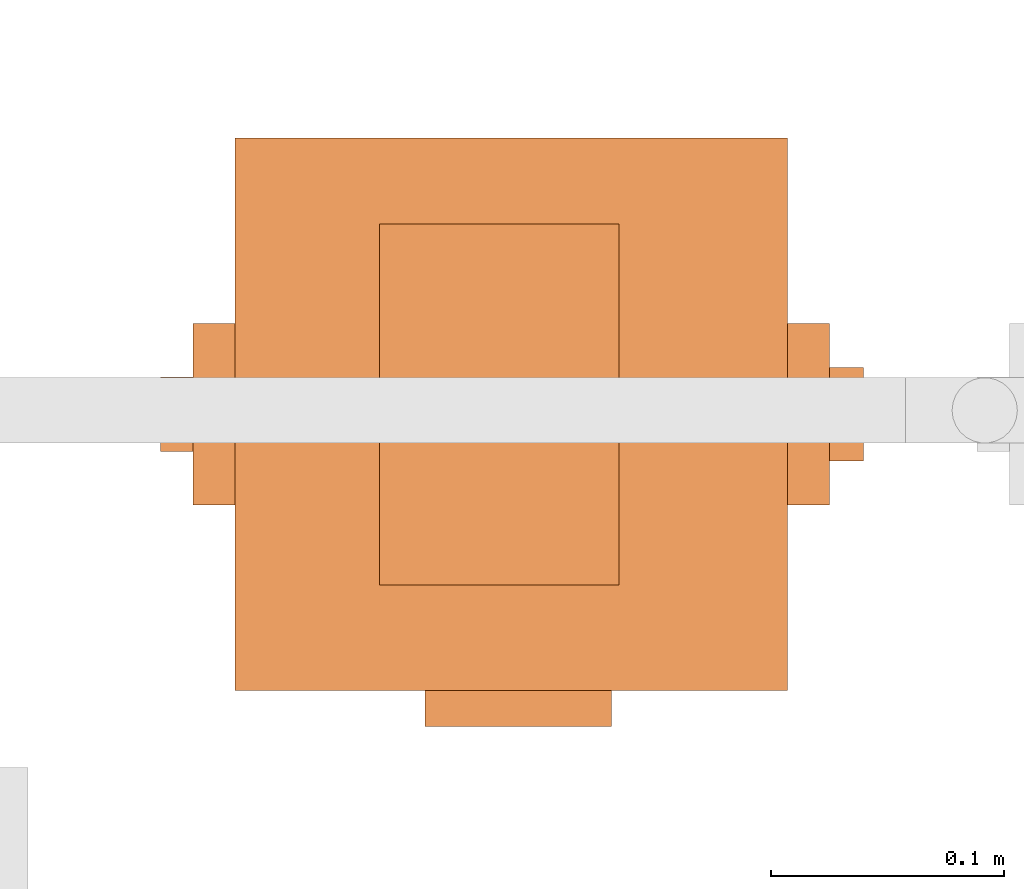
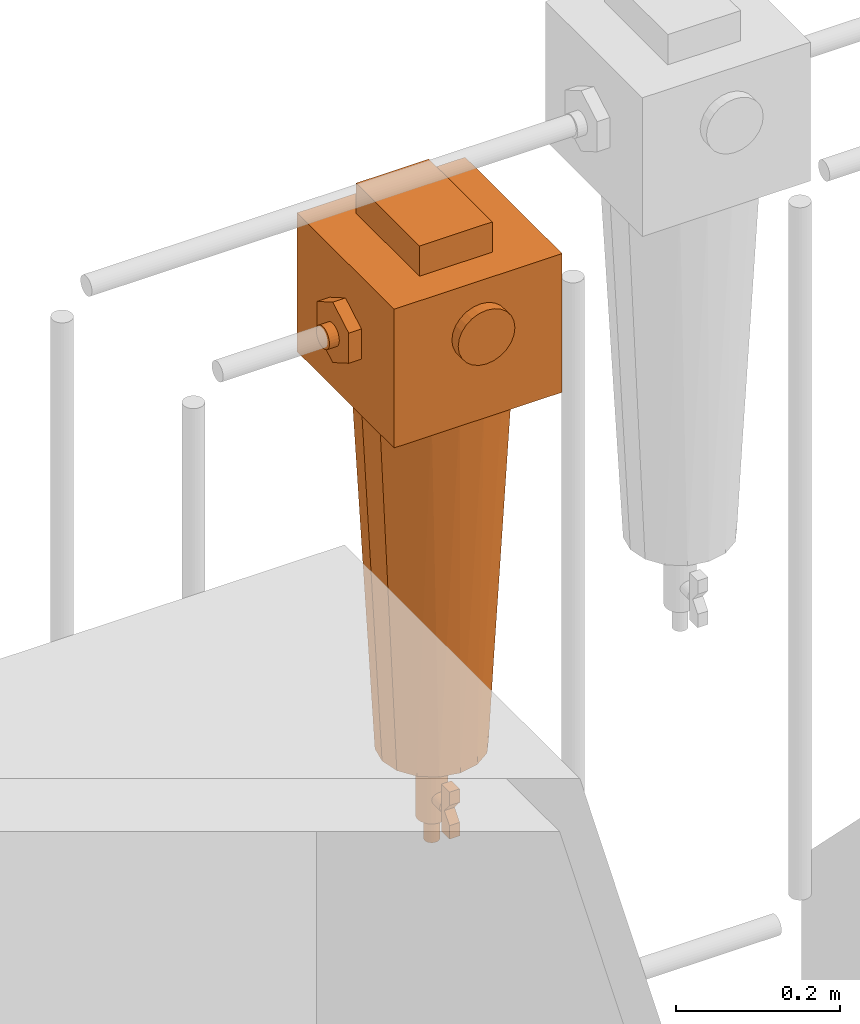
# One storey, part 328 of 331: 1 proxy.
"""IFC2X3 building model written with IfcOpenShell, lengths in millimetres."""

import ifcopenshell
import ifcopenshell.guid

model = None  # the IFC model being written
_history = None  # IfcOwnerHistory: only IFC2X3 demands one
_inside = {}  # id of a spatial element -> (the spatial element, [elements in it])
_under = {}  # id of a project, library or spatial element -> (it, [spatial elements below it])
_declared = {}  # id of a project -> (the project, [libraries it declares])
_typed = {}  # id of a type object -> (the type object, [elements of that type])
_made_of = {}  # id of a material, layer set ... -> (it, [elements and type objects made of it])


def new_model(schema):
    """Start an empty IFC model of exactly this schema.

    Asked for "IFC4X3", IfcOpenShell would pick the latest addendum, in which some entities
    have other attributes; the version numbers below select the first issue.
    IFC2X3 requires an IfcOwnerHistory on every rooted entity: one is made here for all.
    """
    global model, _history
    if schema == "IFC4X3":
        model = ifcopenshell.file(schema_version=(4, 3, 0, 0))
    else:
        model = ifcopenshell.file(schema=schema)
    _inside.clear()
    _under.clear()
    _declared.clear()
    _typed.clear()
    _made_of.clear()
    _history = None
    if model.schema == "IFC2X3":
        org = make("IfcOrganization", Name="unknown")
        user = make(
            "IfcPersonAndOrganization",
            ThePerson=make("IfcPerson", FamilyName="unknown"),
            TheOrganization=org,
        )
        app = make(
            "IfcApplication",
            ApplicationDeveloper=org,
            Version="unknown",
            ApplicationFullName="unknown",
            ApplicationIdentifier="unknown",
        )
        _history = make(
            "IfcOwnerHistory",
            OwningUser=user,
            OwningApplication=app,
            ChangeAction="ADDED",
            CreationDate=0,
        )
    return model


def make(cls, **values):
    """One entity of the class cls with the attributes given. An attribute that is None is left unset."""
    return model.create_entity(
        cls, **{name: value for name, value in values.items() if value is not None}
    )


def entity(cls, *values):
    """Any entity or typed value of the class cls, its attributes in the order of the schema. None: left unset."""
    e = model.create_entity(cls)
    for i, value in enumerate(values):
        if value is not None:
            e[i] = value
    return e


def rooted(cls, **values):
    """An entity with a GlobalId (a new one), such as an element, a storey or a relation."""
    return make(cls, GlobalId=ifcopenshell.guid.new(), OwnerHistory=_history, **values)


def si_unit(unit_type, name, prefix=None):
    """IfcSIUnit, for example si_unit("LENGTHUNIT", "METRE", prefix="MILLI")."""
    return make("IfcSIUnit", UnitType=unit_type, Prefix=prefix, Name=name)


def converted_unit(unit_type, name, factor, base, dimensions=None, offset=None):
    """IfcConversionBasedUnit, such as the inch: factor (a typed value) times the base unit."""
    return make(
        "IfcConversionBasedUnit"
        if offset is None
        else "IfcConversionBasedUnitWithOffset",
        ConversionOffset=offset,
        Dimensions=None
        if dimensions is None
        else entity("IfcDimensionalExponents", *dimensions),
        UnitType=unit_type,
        Name=name,
        ConversionFactor=make(
            "IfcMeasureWithUnit", ValueComponent=factor, UnitComponent=base
        ),
    )


def derived_unit(unit_type, elements):
    """IfcDerivedUnit: a product of units, each with its exponent."""
    return make(
        "IfcDerivedUnit",
        Elements=[
            make("IfcDerivedUnitElement", Unit=unit, Exponent=power)
            for unit, power in elements
        ],
        UnitType=unit_type,
    )


def assignment(units):
    """IfcUnitAssignment: the units of a project."""
    return None if units is None else make("IfcUnitAssignment", Units=units)


def point(xyz):
    """IfcCartesianPoint."""
    return None if xyz is None else make("IfcCartesianPoint", Coordinates=xyz)


def direction(xyz):
    """IfcDirection."""
    return None if xyz is None else make("IfcDirection", DirectionRatios=xyz)


def frame(location, z_axis=None, x_axis=None):
    """IfcAxis2Placement3D, a coordinate frame: its origin and axes. An axis left out is left unset."""
    return make(
        "IfcAxis2Placement3D",
        Location=point(location),
        Axis=direction(z_axis),
        RefDirection=direction(x_axis),
    )


def origin():
    """The frame at (0, 0, 0) with its axes left unset."""
    return frame((0.0, 0.0, 0.0))


def place(relative_to, where):
    """IfcLocalPlacement: puts the frame where relative to a parent placement (None: the world)."""
    return make(
        "IfcLocalPlacement", PlacementRelTo=relative_to, RelativePlacement=where
    )


def context(
    kind, dimensions, precision=None, world=None, true_north=None, identifier=None
):
    """IfcGeometricRepresentationContext, for example the 3D "Model" context."""
    return make(
        "IfcGeometricRepresentationContext",
        ContextIdentifier=identifier,
        ContextType=kind,
        CoordinateSpaceDimension=dimensions,
        Precision=precision,
        WorldCoordinateSystem=world,
        TrueNorth=true_north,
    )


def subcontext(parent, identifier, kind, view, scale=None):
    """IfcGeometricRepresentationSubContext, for example "Body" below "Model"."""
    return make(
        "IfcGeometricRepresentationSubContext",
        ContextIdentifier=identifier,
        ContextType=kind,
        ParentContext=parent,
        TargetScale=scale,
        TargetView=view,
    )


def project(units=None, contexts=None):
    """IfcProject with its units and contexts."""
    return rooted(
        "IfcProject",
        Name="project",
        RepresentationContexts=contexts,
        UnitsInContext=assignment(units),
    )


def spatial(cls, under=None, at=None, **own):
    """A site, building, storey or space (cls), placed at a placement, below another one or the project."""
    s = rooted(cls, ObjectPlacement=at, **own)
    if under is not None:
        _under.setdefault(under.id(), (under, []))[1].append(s)
    return s


def faces_of(points, faces, orient=None, outer=None):
    """IfcFace entities. A face is a list of loops; a loop is a list of indices into points, from 0.

    orient and outer hold one flag for each loop. By default every Orientation is true, the
    first loop of a face is its IfcFaceOuterBound and the others are IfcFaceBound.
    """
    made = []
    for i, loops in enumerate(faces):
        bounds = []
        for j, loop in enumerate(loops):
            is_outer = j == 0 if outer is None else outer[i][j]
            bounds.append(
                make(
                    "IfcFaceOuterBound" if is_outer else "IfcFaceBound",
                    Bound=make("IfcPolyLoop", Polygon=[points[k] for k in loop]),
                    Orientation=True if orient is None else orient[i][j],
                )
            )
        made.append(make("IfcFace", Bounds=bounds))
    return made


def faceted_brep(points, faces, orient=None, outer=None, voids=None):
    """IfcFacetedBrep: a solid bounded by flat faces; with voids (closed shells), ...WithVoids."""
    shared = [point(p) for p in points]
    hull = make("IfcClosedShell", CfsFaces=faces_of(shared, faces, orient, outer))
    if voids is None:
        return make("IfcFacetedBrep", Outer=hull)
    return make(
        "IfcFacetedBrepWithVoids",
        Outer=hull,
        Voids=[
            make(cls, CfsFaces=faces_of(shared, fs, o, b)) for cls, fs, o, b in voids
        ],
    )


def shape(context_of_items, identifier, shape_type, items):
    """IfcShapeRepresentation: the items that make up one representation, for example the "Body"."""
    return make(
        "IfcShapeRepresentation",
        ContextOfItems=context_of_items,
        RepresentationIdentifier=identifier,
        RepresentationType=shape_type,
        Items=items,
    )


def source(mapping_origin, context_of_items, identifier, shape_type, items):
    """IfcRepresentationMap: a shape defined once, which mapped items show again and again."""
    return make(
        "IfcRepresentationMap",
        MappingOrigin=mapping_origin,
        MappedRepresentation=shape(context_of_items, identifier, shape_type, items),
    )


def transform(
    local_origin,
    x_axis=None,
    y_axis=None,
    z_axis=None,
    scale=None,
    scale2=None,
    scale3=None,
    uniform=True,
):
    """IfcCartesianTransformationOperator3D, or its non-uniform kind. x_axis, y_axis, z_axis: its Axis1, 2, 3."""
    if uniform:
        return make(
            "IfcCartesianTransformationOperator3D",
            Axis1=direction(x_axis),
            Axis2=direction(y_axis),
            LocalOrigin=point(local_origin),
            Scale=scale,
            Axis3=direction(z_axis),
        )
    return make(
        "IfcCartesianTransformationOperator3DnonUniform",
        Axis1=direction(x_axis),
        Axis2=direction(y_axis),
        LocalOrigin=point(local_origin),
        Scale=scale,
        Axis3=direction(z_axis),
        Scale2=scale2,
        Scale3=scale3,
    )


def mapped(mapping_source, mapping_target):
    """IfcMappedItem: shows the shape of a source again, moved by a transform."""
    return make(
        "IfcMappedItem", MappingSource=mapping_source, MappingTarget=mapping_target
    )


def material(Name=None, Category=None):
    """IfcMaterial."""
    return make("IfcMaterial", Name=Name, Category=Category)


def material_list(materials):
    """IfcMaterialList."""
    return make("IfcMaterialList", Materials=materials)


def made_of(thing, what):
    """Note that an element or type object is made of a material, layer set ...; save() writes the relation."""
    if what is not None:
        _made_of.setdefault(what.id(), (what, []))[1].append(thing)
    return thing


def type_object(cls, material=None, **own):
    """A type object (cls), such as IfcWallType, which elements share."""
    return made_of(rooted(cls, **own), material)


def type_shapes(of_type, sources):
    """Give a type object the sources (RepresentationMaps) that its elements show as mapped items."""
    of_type.RepresentationMaps = sources


def element(
    cls,
    number,
    at=None,
    inside=None,
    cuts=None,
    type_object=None,
    material=None,
    context=None,
    identifier="Body",
    shape_type=None,
    held_by="IfcProductDefinitionShape",
    body=None,
    shapes=None,
    **own,
):
    """One element of the class cls, such as IfcWall. Its Tag is "e" and its number.

    at: its placement. inside: the storey or other place that contains it. cuts: it is an
    opening in that element (IfcRelVoidsElement). A single representation is given by context,
    identifier, shape_type and body (its items); several are given by shapes. held_by: the class
    of the entity that holds the representations. save() writes the other relations.
    """
    e = rooted(cls, Tag="e%d" % number, ObjectPlacement=at, **own)
    if body is not None:
        shapes = [shape(context, identifier, shape_type, body)]
    if shapes is not None:
        e.Representation = make(held_by, Representations=shapes)
    if inside is not None:
        _inside.setdefault(inside.id(), (inside, []))[1].append(e)
    if cuts is not None:
        rooted(
            "IfcRelVoidsElement", RelatingBuildingElement=cuts, RelatedOpeningElement=e
        )
    if type_object is not None:
        _typed.setdefault(type_object.id(), (type_object, []))[1].append(e)
    return made_of(e, material)


def aggregate(whole, parts):
    """IfcRelAggregates: a whole, such as a stair, and the parts it consists of."""
    return rooted("IfcRelAggregates", RelatingObject=whole, RelatedObjects=parts)


def save(model, path):
    """Write the relations noted so far, then the file.

    IfcRelAggregates (storeys below a building ...), IfcRelContainedInSpatialStructure (elements
    in a storey), IfcRelDefinesByType, IfcRelAssociatesMaterial and IfcRelDeclares: one each for
    every whole, place, type object, material and project.
    """
    for whole, parts in _under.values():
        aggregate(whole, parts)
    for where, things in _inside.values():
        rooted(
            "IfcRelContainedInSpatialStructure",
            RelatedElements=things,
            RelatingStructure=where,
        )
    for kind, things in _typed.values():
        rooted("IfcRelDefinesByType", RelatedObjects=things, RelatingType=kind)
    for what, things in _made_of.values():
        rooted("IfcRelAssociatesMaterial", RelatedObjects=things, RelatingMaterial=what)
    for by, libraries in _declared.values():
        rooted("IfcRelDeclares", RelatingContext=by, RelatedDefinitions=libraries)
    model.write(path)


model = new_model("IFC2X3")

# Units and contexts
model_context = context("Model", 3, precision=0.01, world=origin(), true_north=direction((6.12303176911189e-17, 1.0)))
body_context = subcontext(model_context, "Body", "Model", "MODEL_VIEW")
ifc_project = project(units=[si_unit("LENGTHUNIT", "METRE", prefix="MILLI"), si_unit("AREAUNIT", "SQUARE_METRE"), si_unit("VOLUMEUNIT", "CUBIC_METRE"), converted_unit("PLANEANGLEUNIT", "DEGREE", entity("IfcRatioMeasure", 0.0174532925199433), si_unit("PLANEANGLEUNIT", "RADIAN"), dimensions=[0, 0, 0, 0, 0, 0, 0]), si_unit("MASSUNIT", "GRAM", prefix="KILO"), derived_unit("MASSDENSITYUNIT", [(si_unit("MASSUNIT", "GRAM", prefix="KILO"), 1), (si_unit("LENGTHUNIT", "METRE"), -3)]), derived_unit("MOMENTOFINERTIAUNIT", [(si_unit("LENGTHUNIT", "METRE"), 4)]), si_unit("TIMEUNIT", "SECOND"), si_unit("FREQUENCYUNIT", "HERTZ"), si_unit("THERMODYNAMICTEMPERATUREUNIT", "DEGREE_CELSIUS"), derived_unit("THERMALTRANSMITTANCEUNIT", [(si_unit("MASSUNIT", "GRAM", prefix="KILO"), 1), (si_unit("THERMODYNAMICTEMPERATUREUNIT", "KELVIN"), -1), (si_unit("TIMEUNIT", "SECOND"), -3)]), derived_unit("VOLUMETRICFLOWRATEUNIT", [(si_unit("LENGTHUNIT", "METRE"), 3), (si_unit("TIMEUNIT", "SECOND"), -1)]), derived_unit("MASSFLOWRATEUNIT", [(si_unit("MASSUNIT", "GRAM", prefix="KILO"), 1), (si_unit("TIMEUNIT", "SECOND"), -1)]), derived_unit("ROTATIONALFREQUENCYUNIT", [(si_unit("TIMEUNIT", "SECOND"), -1)]), si_unit("ELECTRICCURRENTUNIT", "AMPERE"), si_unit("ELECTRICVOLTAGEUNIT", "VOLT"), si_unit("POWERUNIT", "WATT"), si_unit("FORCEUNIT", "NEWTON", prefix="KILO"), si_unit("ILLUMINANCEUNIT", "LUX"), si_unit("LUMINOUSFLUXUNIT", "LUMEN"), si_unit("LUMINOUSINTENSITYUNIT", "CANDELA"), derived_unit("USERDEFINED", [(si_unit("MASSUNIT", "GRAM", prefix="KILO"), -1), (si_unit("LENGTHUNIT", "METRE"), -2), (si_unit("TIMEUNIT", "SECOND"), 3), (si_unit("LUMINOUSFLUXUNIT", "LUMEN"), 1)]), derived_unit("LINEARVELOCITYUNIT", [(si_unit("LENGTHUNIT", "METRE"), 1), (si_unit("TIMEUNIT", "SECOND"), -1)]), si_unit("PRESSUREUNIT", "PASCAL"), derived_unit("USERDEFINED", [(si_unit("LENGTHUNIT", "METRE"), -2), (si_unit("MASSUNIT", "GRAM", prefix="KILO"), 1), (si_unit("TIMEUNIT", "SECOND"), -2)]), derived_unit("LINEARFORCEUNIT", [(si_unit("MASSUNIT", "GRAM", prefix="KILO"), 1), (si_unit("LENGTHUNIT", "METRE"), 1), (si_unit("TIMEUNIT", "SECOND"), -2), (si_unit("LENGTHUNIT", "METRE"), -1)]), derived_unit("PLANARFORCEUNIT", [(si_unit("MASSUNIT", "GRAM", prefix="KILO"), 1), (si_unit("LENGTHUNIT", "METRE"), 1), (si_unit("TIMEUNIT", "SECOND"), -2), (si_unit("LENGTHUNIT", "METRE"), -2)])], contexts=[model_context])

# Site, building, storey
site_placement = place(None, frame((0.0, -0.00077364408347762, 0.0)))
site = spatial("IfcSite", under=ifc_project, at=site_placement, CompositionType="ELEMENT")
building_placement = place(site_placement, origin())
building = spatial("IfcBuilding", under=site, at=building_placement, CompositionType="ELEMENT")
storey_placement = place(building_placement, origin())
storey = spatial("IfcBuildingStorey", under=building, at=storey_placement, CompositionType="ELEMENT", Elevation=0.0)

# Proxy
ifc_material_1 = material()
ifc_material_2 = material()
ifc_material_list = material_list([ifc_material_1, ifc_material_2])
building_element_proxy_type = type_object("IfcBuildingElementProxyType", PredefinedType="NOTDEFINED", material=ifc_material_1)
shared_shape = source(origin(), body_context, "Body", "Brep", [
    faceted_brep([(0.0, -133.944326212679, 215.362410286268), (-10.3527618041006, -133.944326212679, 213.999443337831), (-20.0, -133.944326212679, 210.003426437646), (-28.2842712474617, -133.944326212679, 203.64668153373), (-34.6410161513774, -133.944326212679, 195.362410286268), (-38.6370330515627, -133.944326212679, 185.715172090369), (-40.0, -133.944326212679, 175.362410286268), (-38.6370330515627, -133.944326212679, 165.009648482167), (-34.6410161513776, -133.944326212679, 155.362410286268), (-28.2842712474619, -133.944326212679, 147.078139038806), (-20.0, -133.944326212679, 140.721394134891), (-10.3527618041009, -133.944326212679, 136.725377234705), (0.0, -133.944326212679, 135.362410286268), (10.3527618041008, -133.944326212679, 136.725377234705), (20.0, -133.944326212679, 140.721394134891), (28.2842712474618, -133.944326212679, 147.078139038806), (34.6410161513775, -133.944326212679, 155.362410286268), (38.6370330515627, -133.944326212679, 165.009648482167), (40.0, -133.944326212679, 175.362410286268), (38.6370330515628, -133.944326212679, 185.715172090369), (34.6410161513776, -133.944326212679, 195.362410286268), (28.284271247462, -133.944326212679, 203.64668153373), (20.0, -133.944326212679, 210.003426437646), (10.352761804101, -133.944326212679, 213.999443337831), (0.0, -118.499999999999, 135.362410286268), (-10.3527618041009, -118.499999999999, 136.725377234705), (-20.0, -118.499999999999, 140.721394134891), (-28.2842712474619, -118.499999999999, 147.078139038806), (-34.6410161513776, -118.499999999999, 155.362410286268), (-38.6370330515627, -118.499999999999, 165.009648482167), (-40.0, -118.499999999999, 175.362410286268), (-38.6370330515627, -118.499999999999, 185.715172090369), (-34.6410161513774, -118.499999999999, 195.362410286268), (-28.2842712474617, -118.499999999999, 203.64668153373), (-20.0, -118.499999999999, 210.003426437646), (-10.3527618041006, -118.499999999999, 213.999443337831), (0.0, -118.499999999999, 215.362410286268), (10.352761804101, -118.499999999999, 213.999443337831), (20.0, -118.499999999999, 210.003426437646), (28.284271247462, -118.499999999999, 203.64668153373), (34.6410161513776, -118.499999999999, 195.362410286268), (38.6370330515628, -118.499999999999, 185.715172090369), (40.0, -118.499999999999, 175.362410286268), (38.6370330515627, -118.499999999999, 165.009648482167), (34.6410161513775, -118.499999999999, 155.362410286268), (28.2842712474618, -118.499999999999, 147.078139038806), (20.0, -118.499999999999, 140.721394134891), (10.3527618041008, -118.499999999999, 136.725377234705)], [[[0, 1, 2, 3, 4, 5, 6, 7, 8, 9, 10, 11, 12, 13, 14, 15, 16, 17, 18, 19, 20, 21, 22, 23]], [[24, 25, 26, 27, 28, 29, 30, 31, 32, 33, 34, 35, 36, 37, 38, 39, 40, 41, 42, 43, 44, 45, 46, 47]], [[41, 19, 18, 42]], [[40, 20, 19, 41]], [[22, 21, 39, 38]], [[40, 39, 21, 20]], [[23, 22, 38, 37]], [[0, 23, 37, 36]], [[35, 1, 0, 36]], [[34, 2, 1, 35]], [[4, 3, 33, 32]], [[34, 33, 3, 2]], [[5, 4, 32, 31]], [[6, 5, 31, 30]], [[29, 7, 6, 30]], [[28, 8, 7, 29]], [[10, 9, 27, 26]], [[28, 27, 9, 8]], [[11, 10, 26, 25]], [[12, 11, 25, 24]], [[47, 13, 12, 24]], [[46, 14, 13, 47]], [[16, 15, 45, 44]], [[46, 45, 15, 14]], [[17, 16, 44, 43]], [[18, 17, 43, 42]]]),
    faceted_brep([(43.1099584355239, 81.5000000000009, 295.027035784925), (-59.5, 81.5000000000009, 295.027035784925), (-59.5, -73.1694472627613, 295.027035784925), (43.1099584355239, -73.1694472627613, 295.027035784925), (43.1099584355239, 81.5000000000009, 250.0), (43.1099584355239, -73.1694472627613, 250.0), (-59.5, -73.1694472627613, 250.0), (-59.5, 81.5000000000009, 250.0)], [[[0, 1, 2, 3]], [[4, 5, 6, 7]], [[1, 0, 4, 7]], [[2, 1, 7, 6]], [[3, 2, 6, 5]], [[0, 3, 5, 4]]]),
    faceted_brep([(6.83332917429858, -36.7004123407108, -547.095544544356), (6.83332917429858, -56.7004123407108, -547.095544544356), (6.83332917429858, -56.7004123407108, -567.095544544356), (6.83332917429858, -44.1139178730516, -582.095544544356), (6.83332917429858, -56.7004123407108, -597.095544544356), (6.83332917429858, -56.7004123407109, -617.095544544356), (6.83332917429858, -36.7004123407109, -617.095544544356), (6.83332917429858, -36.7004123407108, -582.095544544356), (-7.69905295378288, -36.7004123407108, -547.095544544356), (-7.69905295378288, -36.7004123407108, -582.095544544356), (-7.69905295378288, -36.7004123407109, -617.095544544356), (-7.69905295378288, -56.7004123407109, -617.095544544356), (-7.69905295378288, -56.7004123407108, -597.095544544356), (-7.69905295378288, -44.1139178730516, -582.095544544356), (-7.69905295378288, -56.7004123407108, -567.095544544356), (-7.69905295378288, -56.7004123407108, -547.095544544356)], [[[0, 1, 2, 3, 4, 5, 6, 7]], [[8, 9, 10, 11, 12, 13, 14, 15]], [[1, 0, 8, 15]], [[2, 1, 15, 14]], [[3, 2, 14, 13]], [[4, 3, 13, 12]], [[5, 4, 12, 11]], [[6, 5, 11, 10]], [[7, 6, 10, 9]], [[0, 7, 9, 8]]]),
    faceted_brep([(-5.0, -36.7004123407108, -573.435290506511), (-7.07106781186544, -36.7004123407108, -575.02447673249), (-8.66025403784436, -36.7004123407108, -577.095544544356), (-9.65925826289067, -36.7004123407108, -579.50735409333), (-10.0, -36.7004123407108, -582.095544544356), (-9.65925826289068, -36.7004123407108, -584.683734995381), (-8.66025403784439, -36.7004123407108, -587.095544544356), (-7.07106781186548, -36.7004123407108, -589.166612356221), (-5.0, -36.7004123407108, -590.7557985822), (-2.58819045102522, -36.7004123407108, -591.754802807246), (0.0, -36.7004123407108, -592.095544544356), (2.58819045102519, -36.7004123407108, -591.754802807246), (5.0, -36.7004123407108, -590.7557985822), (7.07106781186546, -36.7004123407108, -589.166612356221), (8.66025403784437, -36.7004123407108, -587.095544544356), (9.65925826289068, -36.7004123407108, -584.683734995381), (10.0, -36.7004123407108, -582.095544544356), (9.65925826289069, -36.7004123407108, -579.50735409333), (8.66025403784441, -36.7004123407108, -577.095544544356), (7.0710678118655, -36.7004123407108, -575.02447673249), (5.0, -36.7004123407108, -573.435290506511), (2.58819045102525, -36.7004123407108, -572.436286281465), (0.0, -36.7004123407108, -572.095544544356), (-2.58819045102516, -36.7004123407108, -572.436286281465), (2.58819045102519, -9.5868948994194, -591.754802807246), (0.0, -9.5868948994194, -592.095544544356), (-2.58819045102522, -9.5868948994194, -591.754802807246), (-5.0, -9.5868948994194, -590.7557985822), (-7.07106781186548, -9.5868948994194, -589.166612356221), (-8.66025403784439, -9.5868948994194, -587.095544544356), (-9.65925826289068, -9.5868948994194, -584.683734995381), (-10.0, -9.5868948994194, -582.095544544356), (-9.65925826289067, -9.5868948994194, -579.50735409333), (-8.66025403784436, -9.5868948994194, -577.095544544356), (-7.07106781186544, -9.5868948994194, -575.02447673249), (-5.0, -9.5868948994194, -573.435290506511), (-2.58819045102516, -9.5868948994194, -572.436286281465), (0.0, -9.5868948994194, -572.095544544356), (2.58819045102525, -9.5868948994194, -572.436286281465), (5.0, -9.5868948994194, -573.435290506511), (7.0710678118655, -9.5868948994194, -575.02447673249), (8.66025403784441, -9.5868948994194, -577.095544544356), (9.65925826289069, -9.5868948994194, -579.50735409333), (10.0, -9.5868948994194, -582.095544544356), (9.65925826289068, -9.5868948994194, -584.683734995381), (8.66025403784437, -9.5868948994194, -587.095544544356), (7.07106781186546, -9.5868948994194, -589.166612356221), (5.0, -9.5868948994194, -590.7557985822)], [[[0, 1, 2, 3, 4, 5, 6, 7, 8, 9, 10, 11, 12, 13, 14, 15, 16, 17, 18, 19, 20, 21, 22, 23]], [[24, 25, 26, 27, 28, 29, 30, 31, 32, 33, 34, 35, 36, 37, 38, 39, 40, 41, 42, 43, 44, 45, 46, 47]], [[42, 17, 16, 43]], [[41, 18, 17, 42]], [[20, 19, 40, 39]], [[41, 40, 19, 18]], [[21, 20, 39, 38]], [[22, 21, 38, 37]], [[36, 23, 22, 37]], [[35, 0, 23, 36]], [[2, 1, 34, 33]], [[35, 34, 1, 0]], [[3, 2, 33, 32]], [[4, 3, 32, 31]], [[30, 5, 4, 31]], [[29, 6, 5, 30]], [[8, 7, 28, 27]], [[29, 28, 7, 6]], [[9, 8, 27, 26]], [[10, 9, 26, 25]], [[24, 11, 10, 25]], [[47, 12, 11, 24]], [[14, 13, 46, 45]], [[47, 46, 13, 12]], [[15, 14, 45, 44]], [[16, 15, 44, 43]]]),
    faceted_brep([(5.17638090205032, -19.3185165257814, -545.770195770574), (10.0, -17.3205080756888, -545.770195770574), (14.1421356237309, -14.142135623731, -545.770195770574), (17.3205080756887, -10.0, -545.770195770574), (19.3185165257813, -5.17638090205054, -545.770195770574), (20.0, 0.0, -545.770195770574), (19.3185165257814, 5.17638090205041, -545.770195770574), (17.3205080756888, 10.0, -545.770195770574), (14.142135623731, 14.1421356237309, -545.770195770574), (10.0, 17.3205080756888, -545.770195770574), (5.17638090205044, 19.3185165257814, -545.770195770574), (0.0, 20.0, -545.770195770574), (-5.17638090205038, 19.3185165257814, -545.770195770574), (-10.0, 17.3205080756888, -545.770195770574), (-14.1421356237309, 14.142135623731, -545.770195770574), (-17.3205080756888, 10.0, -545.770195770574), (-19.3185165257814, 5.17638090205047, -545.770195770574), (-20.0, 0.0, -545.770195770574), (-19.3185165257814, -5.17638090205035, -545.770195770574), (-17.3205080756888, -10.0, -545.770195770574), (-14.142135623731, -14.1421356237309, -545.770195770574), (-10.0, -17.3205080756887, -545.770195770574), (-5.1763809020505, -19.3185165257813, -545.770195770574), (0.0, -20.0, -545.770195770574), (0.0, 20.0, -617.574154599676), (5.17638090205044, 19.3185165257814, -617.574154599676), (10.0, 17.3205080756888, -617.574154599676), (14.142135623731, 14.1421356237309, -617.574154599676), (17.3205080756888, 10.0, -617.574154599676), (19.3185165257814, 5.17638090205041, -617.574154599676), (20.0, 0.0, -617.574154599676), (19.3185165257813, -5.17638090205054, -617.574154599676), (17.3205080756887, -10.0, -617.574154599676), (14.1421356237309, -14.142135623731, -617.574154599676), (10.0, -17.3205080756888, -617.574154599676), (5.17638090205032, -19.3185165257814, -617.574154599676), (0.0, -20.0, -617.574154599676), (-5.1763809020505, -19.3185165257813, -617.574154599676), (-10.0, -17.3205080756887, -617.574154599676), (-14.142135623731, -14.1421356237309, -617.574154599676), (-17.3205080756888, -10.0, -617.574154599676), (-19.3185165257814, -5.17638090205035, -617.574154599676), (-20.0, 0.0, -617.574154599676), (-19.3185165257814, 5.17638090205047, -617.574154599676), (-17.3205080756888, 10.0, -617.574154599676), (-14.1421356237309, 14.142135623731, -617.574154599676), (-10.0, 17.3205080756888, -617.574154599676), (-5.17638090205038, 19.3185165257814, -617.574154599676)], [[[0, 1, 2, 3, 4, 5, 6, 7, 8, 9, 10, 11, 12, 13, 14, 15, 16, 17, 18, 19, 20, 21, 22, 23]], [[24, 25, 26, 27, 28, 29, 30, 31, 32, 33, 34, 35, 36, 37, 38, 39, 40, 41, 42, 43, 44, 45, 46, 47]], [[18, 41, 40, 19]], [[39, 20, 19, 40]], [[21, 38, 37, 22]], [[39, 38, 21, 20]], [[22, 37, 36, 23]], [[41, 18, 17, 42]], [[0, 35, 34, 1]], [[33, 2, 1, 34]], [[3, 32, 31, 4]], [[33, 32, 3, 2]], [[4, 31, 30, 5]], [[35, 0, 23, 36]], [[30, 29, 6, 5]], [[9, 26, 25, 10]], [[26, 9, 8, 27]], [[10, 25, 24, 11]], [[29, 28, 7, 6]], [[28, 27, 8, 7]], [[12, 47, 46, 13]], [[45, 14, 13, 46]], [[15, 44, 43, 16]], [[45, 44, 15, 14]], [[16, 43, 42, 17]], [[47, 12, 11, 24]]]),
    faceted_brep([(2.58819045102516, -9.6592582628907, -513.126445637314), (5.0, -8.66025403784441, -513.126445637314), (7.07106781186544, -7.07106781186551, -513.126445637314), (8.66025403784436, -5.0, -513.126445637314), (9.65925826289067, -2.58819045102527, -513.126445637314), (10.0, 0.0, -513.126445637314), (9.65925826289068, 2.58819045102521, -513.126445637314), (8.66025403784439, 5.0, -513.126445637314), (7.07106781186548, 7.07106781186547, -513.126445637314), (5.0, 8.66025403784438, -513.126445637314), (2.58819045102522, 9.65925826289068, -513.126445637314), (0.0, 10.0, -513.126445637314), (-2.58819045102519, 9.65925826289069, -513.126445637314), (-5.0, 8.6602540378444, -513.126445637314), (-7.07106781186546, 7.07106781186549, -513.126445637314), (-8.66025403784437, 5.0, -513.126445637314), (-9.65925826289068, 2.58819045102524, -513.126445637314), (-10.0, 0.0, -513.126445637314), (-9.65925826289069, -2.58819045102517, -513.126445637314), (-8.66025403784441, -5.0, -513.126445637314), (-7.0710678118655, -7.07106781186545, -513.126445637314), (-5.0, -8.66025403784437, -513.126445637314), (-2.58819045102525, -9.65925826289067, -513.126445637314), (0.0, -10.0, -513.126445637314), (0.0, 10.0, -652.602700358113), (2.58819045102522, 9.65925826289068, -652.602700358113), (5.0, 8.66025403784438, -652.602700358113), (7.07106781186548, 7.07106781186547, -652.602700358113), (8.66025403784439, 5.0, -652.602700358113), (9.65925826289068, 2.58819045102521, -652.602700358113), (10.0, 0.0, -652.602700358113), (9.65925826289067, -2.58819045102527, -652.602700358113), (8.66025403784436, -5.0, -652.602700358113), (7.07106781186544, -7.07106781186551, -652.602700358113), (5.0, -8.66025403784441, -652.602700358113), (2.58819045102516, -9.6592582628907, -652.602700358113), (0.0, -10.0, -652.602700358113), (-2.58819045102525, -9.65925826289067, -652.602700358113), (-5.0, -8.66025403784437, -652.602700358113), (-7.0710678118655, -7.07106781186545, -652.602700358113), (-8.66025403784441, -5.0, -652.602700358113), (-9.65925826289069, -2.58819045102517, -652.602700358113), (-10.0, 0.0, -652.602700358113), (-9.65925826289068, 2.58819045102524, -652.602700358113), (-8.66025403784437, 5.0, -652.602700358113), (-7.07106781186546, 7.07106781186549, -652.602700358113), (-5.0, 8.6602540378444, -652.602700358113), (-2.58819045102519, 9.65925826289069, -652.602700358113)], [[[0, 1, 2, 3, 4, 5, 6, 7, 8, 9, 10, 11, 12, 13, 14, 15, 16, 17, 18, 19, 20, 21, 22, 23]], [[24, 25, 26, 27, 28, 29, 30, 31, 32, 33, 34, 35, 36, 37, 38, 39, 40, 41, 42, 43, 44, 45, 46, 47]], [[41, 18, 17, 42]], [[40, 19, 18, 41]], [[21, 20, 39, 38]], [[40, 39, 20, 19]], [[22, 21, 38, 37]], [[23, 22, 37, 36]], [[35, 0, 23, 36]], [[3, 32, 31, 4]], [[32, 3, 2, 33]], [[4, 31, 30, 5]], [[0, 35, 34, 1]], [[1, 34, 33, 2]], [[29, 6, 5, 30]], [[28, 7, 6, 29]], [[9, 8, 27, 26]], [[28, 27, 8, 7]], [[9, 26, 25, 10]], [[24, 11, 10, 25]], [[14, 13, 46, 45]], [[15, 44, 43, 16]], [[45, 44, 15, 14]], [[16, 43, 42, 17]], [[47, 46, 13, 12]], [[12, 11, 24, 47]]]),
    faceted_brep([(-121.5, 0.0, 105.0), (-121.5, 38.9711431702997, 127.5), (-121.5, 38.9711431702998, 172.5), (-121.5, 0.0, 195.0), (-121.5, -38.9711431702996, 172.500000000001), (-121.5, -38.9711431702999, 127.500000000001), (-139.459825523657, 0.0, 105.0), (-139.459825523657, -38.9711431702999, 127.500000000001), (-139.459825523657, -38.9711431702996, 172.500000000001), (-139.459825523657, 0.0, 195.0), (-139.459825523657, 38.9711431702998, 172.5), (-139.459825523657, 38.9711431702997, 127.5)], [[[0, 1, 2, 3, 4, 5]], [[6, 7, 8, 9, 10, 11]], [[1, 0, 6, 11]], [[2, 1, 11, 10]], [[3, 2, 10, 9]], [[4, 3, 9, 8]], [[5, 4, 8, 7]], [[0, 5, 7, 6]]]),
    faceted_brep([(133.459825523657, 0.0, 105.0), (133.459825523657, 38.9711431702997, 127.5), (133.459825523657, 38.9711431702998, 172.5), (133.459825523657, 0.0, 195.0), (133.459825523657, -38.9711431702996, 172.5), (133.459825523657, -38.9711431702999, 127.5), (115.5, 0.0, 105.0), (115.5, -38.9711431702999, 127.5), (115.5, -38.9711431702996, 172.5), (115.5, 0.0, 195.0), (115.5, 38.9711431702998, 172.5), (115.5, 38.9711431702997, 127.5)], [[[0, 1, 2, 3, 4, 5]], [[6, 7, 8, 9, 10, 11]], [[1, 0, 6, 11]], [[2, 1, 11, 10]], [[3, 2, 10, 9]], [[4, 3, 9, 8]], [[5, 4, 8, 7]], [[0, 5, 7, 6]]]),
    faceted_brep([(-153.337340449734, 4.14110472164035, 162.941988222046), (-153.337340449734, 8.0, 161.343581461972), (-153.337340449734, 11.3137084989848, 158.800883500406), (-153.337340449734, 13.856406460551, 155.487175001421), (-153.337340449734, 15.4548132206251, 151.628279723061), (-153.337340449734, 16.0, 147.487175001421), (-153.337340449734, 15.4548132206251, 143.346070279781), (-153.337340449734, 13.856406460551, 139.487175001421), (-153.337340449734, 11.3137084989847, 136.173466502436), (-153.337340449734, 8.0, 133.63076854087), (-153.337340449734, 4.14110472164026, 132.032361780796), (-153.337340449734, 0.0, 131.487175001421), (-153.337340449734, -4.1411047216404, 132.032361780796), (-153.337340449734, -8.0, 133.63076854087), (-153.337340449734, -11.3137084989848, 136.173466502436), (-153.337340449734, -13.8564064605511, 139.487175001421), (-153.337340449734, -15.4548132206251, 143.346070279781), (-153.337340449734, -16.0, 147.487175001421), (-153.337340449734, -15.4548132206251, 151.628279723061), (-153.337340449734, -13.856406460551, 155.487175001421), (-153.337340449734, -11.3137084989847, 158.800883500406), (-153.337340449734, -8.0, 161.343581461972), (-153.337340449734, -4.14110472164031, 162.941988222046), (-153.337340449734, 0.0, 163.487175001421), (-139.459825523657, 4.14110472164026, 132.032361780796), (-139.459825523657, 8.0, 133.63076854087), (-139.459825523657, 11.3137084989847, 136.173466502436), (-139.459825523657, 13.856406460551, 139.487175001421), (-139.459825523657, 15.4548132206251, 143.346070279781), (-139.459825523657, 16.0, 147.487175001421), (-139.459825523657, 15.4548132206251, 151.628279723061), (-139.459825523657, 13.856406460551, 155.487175001421), (-139.459825523657, 11.3137084989848, 158.800883500406), (-139.459825523657, 8.0, 161.343581461972), (-139.459825523657, 4.14110472164035, 162.941988222046), (-139.459825523657, 0.0, 163.487175001421), (-139.459825523657, -4.14110472164031, 162.941988222046), (-139.459825523657, -8.0, 161.343581461972), (-139.459825523657, -11.3137084989847, 158.800883500406), (-139.459825523657, -13.856406460551, 155.487175001421), (-139.459825523657, -15.4548132206251, 151.628279723061), (-139.459825523657, -16.0, 147.487175001421), (-139.459825523657, -15.4548132206251, 143.346070279781), (-139.459825523657, -13.8564064605511, 139.487175001421), (-139.459825523657, -11.3137084989848, 136.173466502436), (-139.459825523657, -8.0, 133.63076854087), (-139.459825523657, -4.1411047216404, 132.032361780796), (-139.459825523657, 0.0, 131.487175001421)], [[[0, 1, 2, 3, 4, 5, 6, 7, 8, 9, 10, 11, 12, 13, 14, 15, 16, 17, 18, 19, 20, 21, 22, 23]], [[24, 25, 26, 27, 28, 29, 30, 31, 32, 33, 34, 35, 36, 37, 38, 39, 40, 41, 42, 43, 44, 45, 46, 47]], [[16, 42, 41, 17]], [[15, 43, 42, 16]], [[45, 44, 14, 13]], [[15, 14, 44, 43]], [[46, 45, 13, 12]], [[47, 46, 12, 11]], [[10, 24, 47, 11]], [[9, 25, 24, 10]], [[27, 26, 8, 7]], [[9, 8, 26, 25]], [[28, 27, 7, 6]], [[29, 28, 6, 5]], [[4, 30, 29, 5]], [[3, 31, 30, 4]], [[33, 32, 2, 1]], [[3, 2, 32, 31]], [[34, 33, 1, 0]], [[35, 34, 0, 23]], [[22, 36, 35, 23]], [[21, 37, 36, 22]], [[21, 20, 38, 37]], [[20, 19, 39, 38]], [[18, 40, 39, 19]], [[18, 17, 41, 40]]]),
    faceted_brep([(147.995639473242, -10.0, 165.507212653008), (147.995639473242, -14.1421356237309, 162.32884020105), (147.995639473242, -17.3205080756887, 158.186704577319), (147.995639473242, -19.3185165257813, 153.36308547937), (147.995639473242, -20.0, 148.186704577319), (147.995639473242, -19.3185165257814, 143.010323675269), (147.995639473242, -17.3205080756888, 138.186704577319), (147.995639473242, -14.142135623731, 134.044568953588), (147.995639473242, -10.0, 130.86619650163), (147.995639473242, -5.17638090205044, 128.868188051538), (147.995639473242, 0.0, 128.186704577319), (147.995639473242, 5.17638090205038, 128.868188051538), (147.995639473242, 10.0, 130.86619650163), (147.995639473242, 14.1421356237309, 134.044568953588), (147.995639473242, 17.3205080756888, 138.186704577319), (147.995639473242, 19.3185165257814, 143.010323675269), (147.995639473242, 20.0, 148.186704577319), (147.995639473242, 19.3185165257814, 153.363085479369), (147.995639473242, 17.3205080756888, 158.186704577319), (147.995639473242, 14.142135623731, 162.32884020105), (147.995639473242, 10.0, 165.507212653008), (147.995639473242, 5.1763809020505, 167.5052211031), (147.995639473242, 0.0, 168.186704577319), (147.995639473242, -5.17638090205032, 167.505221103101), (133.459825523657, 0.0, 128.186704577319), (133.459825523657, -5.17638090205044, 128.868188051538), (133.459825523657, -10.0, 130.86619650163), (133.459825523657, -14.142135623731, 134.044568953588), (133.459825523657, -17.3205080756888, 138.186704577319), (133.459825523657, -19.3185165257814, 143.010323675269), (133.459825523657, -20.0, 148.186704577319), (133.459825523657, -19.3185165257813, 153.36308547937), (133.459825523657, -17.3205080756887, 158.186704577319), (133.459825523657, -14.1421356237309, 162.32884020105), (133.459825523657, -10.0, 165.507212653008), (133.459825523657, -5.17638090205032, 167.505221103101), (133.459825523657, 0.0, 168.186704577319), (133.459825523657, 5.1763809020505, 167.5052211031), (133.459825523657, 10.0, 165.507212653008), (133.459825523657, 14.142135623731, 162.32884020105), (133.459825523657, 17.3205080756888, 158.186704577319), (133.459825523657, 19.3185165257814, 153.363085479369), (133.459825523657, 20.0, 148.186704577319), (133.459825523657, 19.3185165257814, 143.010323675269), (133.459825523657, 17.3205080756888, 138.186704577319), (133.459825523657, 14.1421356237309, 134.044568953588), (133.459825523657, 10.0, 130.86619650163), (133.459825523657, 5.17638090205038, 128.868188051538)], [[[0, 1, 2, 3, 4, 5, 6, 7, 8, 9, 10, 11, 12, 13, 14, 15, 16, 17, 18, 19, 20, 21, 22, 23]], [[24, 25, 26, 27, 28, 29, 30, 31, 32, 33, 34, 35, 36, 37, 38, 39, 40, 41, 42, 43, 44, 45, 46, 47]], [[41, 17, 16, 42]], [[40, 18, 17, 41]], [[20, 19, 39, 38]], [[40, 39, 19, 18]], [[21, 20, 38, 37]], [[22, 21, 37, 36]], [[35, 23, 22, 36]], [[34, 0, 23, 35]], [[2, 1, 33, 32]], [[34, 33, 1, 0]], [[3, 2, 32, 31]], [[4, 3, 31, 30]], [[29, 5, 4, 30]], [[28, 6, 5, 29]], [[8, 7, 27, 26]], [[28, 27, 7, 6]], [[9, 8, 26, 25]], [[10, 9, 25, 24]], [[47, 11, 10, 24]], [[46, 12, 11, 47]], [[45, 44, 14, 13]], [[46, 45, 13, 12]], [[15, 43, 42, 16]], [[15, 14, 44, 43]]]),
    faceted_brep([(-64.6715672757874, -26.7878402655554, -513.126445637314), (-67.3357836378922, -13.3939201327778, -513.126445637314), (-70.0, 0.0, -513.126445637314), (-67.3357836378947, 13.3939201327778, -513.126445637314), (-64.6715672757897, 26.7878402655559, -513.126445637314), (-57.0845209794239, 38.1426574743067, -513.126445637314), (-49.497474683058, 49.4974746830576, -513.126445637314), (-38.1426574743071, 57.0845209794232, -513.126445637314), (-26.7878402655561, 64.6715672757889, -513.126445637314), (-13.3939201327782, 67.3357836378936, -513.126445637314), (0.0, 70.0, -513.126445637314), (13.3939201327774, 67.3357836378933, -513.126445637314), (26.7878402655551, 64.6715672757882, -513.126445637314), (38.1426574743057, 57.0845209794225, -513.126445637314), (49.4974746830562, 49.4974746830568, -513.126445637314), (57.0845209794218, 38.1426574743062, -513.126445637314), (64.6715672757873, 26.7878402655556, -513.126445637314), (67.3357836378922, 13.393920132778, -513.126445637314), (70.0, 0.0, -513.126445637314), (67.3357836378946, -13.393920132778, -513.126445637314), (64.6715672757896, -26.7878402655561, -513.126445637314), (57.0845209794237, -38.1426574743069, -513.126445637314), (49.4974746830578, -49.4974746830577, -513.126445637314), (38.1426574743069, -57.0845209794233, -513.126445637314), (26.7878402655559, -64.6715672757889, -513.126445637314), (13.393920132778, -67.3357836378937, -513.126445637314), (0.0, -70.0, -513.126445637314), (-13.3939201327776, -67.3357836378932, -513.126445637314), (-26.7878402655553, -64.6715672757881, -513.126445637314), (-38.1426574743059, -57.0845209794224, -513.126445637314), (-49.4974746830564, -49.4974746830566, -513.126445637314), (-57.0845209794219, -38.142657474306, -513.126445637314), (-100.0, 0.0, 43.2779488123182), (-93.9692620785884, -34.2020143325663, 43.2779488123182), (-76.6044443118959, -64.2787609686527, 43.2779488123182), (-50.0, -86.6025403784423, 43.2779488123182), (-17.3648177666926, -98.4807753012194, 43.2779488123182), (17.364817766693, -98.4807753012198, 43.2779488123182), (50.0, -86.6025403784433, 43.2779488123182), (76.6044443118976, -64.2787609686537, 43.2779488123182), (93.9692620785908, -34.2020143325668, 43.2779488123182), (100.0, 0.0, 43.2779488123182), (93.9692620785883, 34.2020143325666, 43.2779488123182), (76.6044443118957, 64.2787609686529, 43.2779488123182), (50.0, 86.6025403784425, 43.2779488123182), (17.3648177666923, 98.4807753012194, 43.2779488123182), (-17.3648177666933, 98.4807753012197, 43.2779488123182), (-50.0, 86.6025403784431, 43.2779488123182), (-76.6044443118979, 64.2787609686534, 43.2779488123182), (-93.9692620785909, 34.2020143325665, 43.2779488123182)], [[[0, 1, 2, 3, 4, 5, 6, 7, 8, 9, 10, 11, 12, 13, 14, 15, 16, 17, 18, 19, 20, 21, 22, 23, 24, 25, 26, 27, 28, 29, 30, 31]], [[32, 33, 34, 35, 36, 37, 38, 39, 40, 41, 42, 43, 44, 45, 46, 47, 48, 49]], [[41, 17, 42]], [[11, 10, 45, 12]], [[44, 14, 13, 12]], [[15, 14, 43]], [[49, 4, 3]], [[42, 15, 43]], [[14, 44, 43]], [[15, 42, 16]], [[12, 45, 44]], [[46, 10, 9, 8]], [[17, 16, 42]], [[4, 49, 5]], [[17, 41, 18]], [[2, 32, 3]], [[6, 47, 8, 7]], [[8, 47, 46]], [[48, 6, 5]], [[6, 48, 47]], [[3, 32, 49]], [[48, 5, 49]], [[10, 46, 45]], [[32, 1, 33]], [[27, 26, 36, 28]], [[35, 30, 29, 28]], [[31, 30, 34]], [[40, 20, 19]], [[33, 31, 34]], [[30, 35, 34]], [[31, 33, 0]], [[28, 36, 35]], [[37, 26, 25, 24]], [[1, 0, 33]], [[20, 40, 21]], [[1, 32, 2]], [[18, 41, 19]], [[22, 38, 24, 23]], [[24, 38, 37]], [[39, 22, 21]], [[22, 39, 38]], [[19, 41, 40]], [[39, 21, 40]], [[26, 37, 36]]]),
    faceted_brep([(-121.5, 118.5, 250.0), (-121.5, -118.499999999999, 250.0), (115.5, -118.5, 250.0), (115.5, 118.5, 250.0), (-121.5, 118.5, 43.2779488123182), (115.5, 118.5, 43.2779488123182), (115.5, -118.5, 43.2779488123182), (-121.5, -118.499999999999, 43.2779488123182)], [[[0, 1, 2, 3]], [[4, 5, 6, 7]], [[1, 0, 4, 7]], [[2, 1, 7, 6]], [[3, 2, 6, 5]], [[0, 3, 5, 4]]]),
])
type_shapes(building_element_proxy_type, [shared_shape])
proxy_placement = place(storey_placement, frame((53340.1085349589, -688.500101698472, 550.0)))
element("IfcBuildingElementProxy", 1, at=proxy_placement, inside=storey, type_object=building_element_proxy_type, material=ifc_material_list, context=body_context, shape_type="MappedRepresentation", body=[
    mapped(shared_shape, transform((0.0, 0.0, 0.0), scale=1.0)),
])

save(model, "model.ifc")
